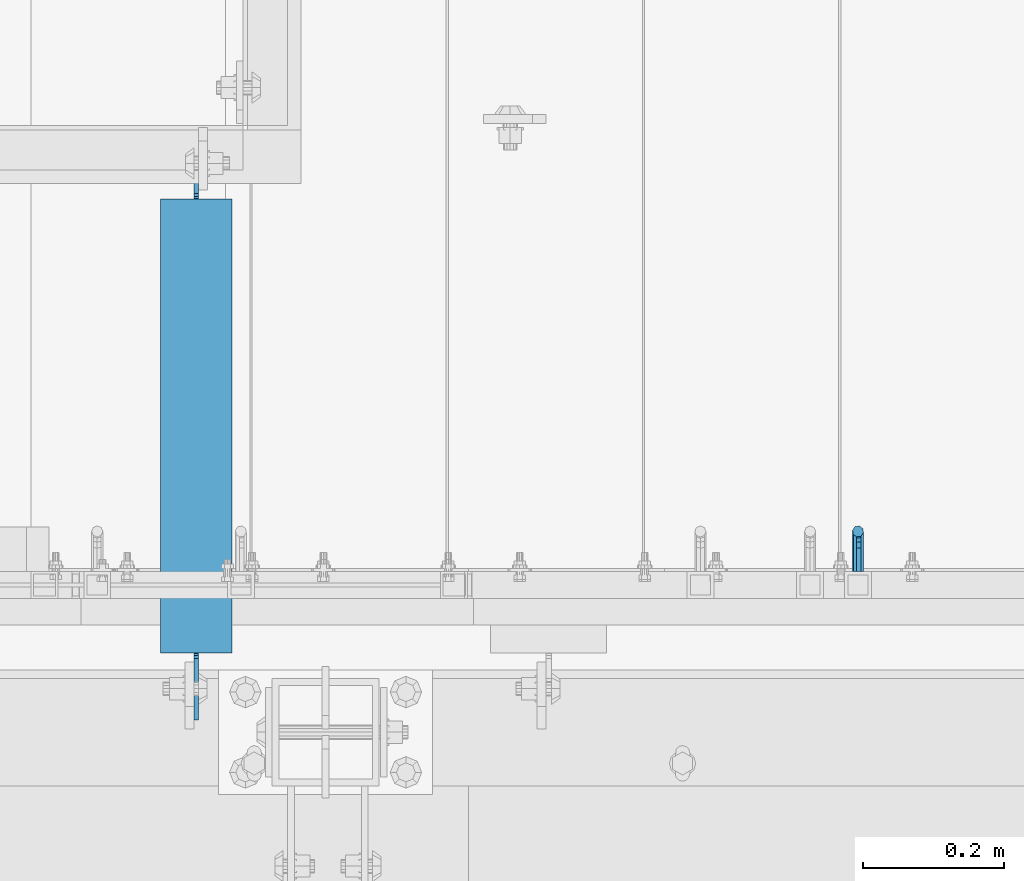
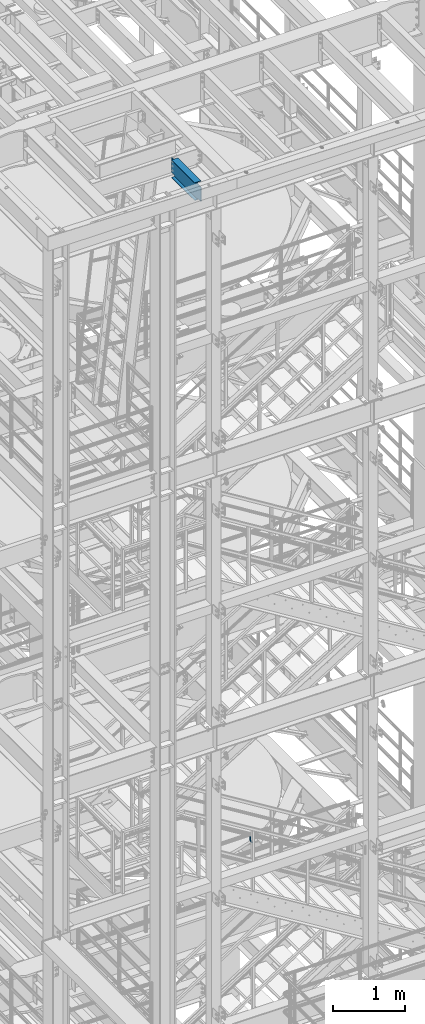
# One storey, part 1140 of 1876: 2 beams, 2 elements without a shape of their own.
"""IFC2X3 building model written with IfcOpenShell, lengths in millimetres."""

from ifc_helpers import new_model, si_unit, frame, origin_with_axes, place, context, subcontext, project, spatial, faceted_brep, material, type_object, element, aggregate, save


model = new_model("IFC2X3")

# Units and contexts
model_context = context("Model", 3, precision=1e-05, world=origin_with_axes())
body_context = subcontext(model_context, "Body", "Model", "MODEL_VIEW")
ifc_project = project(units=[si_unit("LENGTHUNIT", "METRE", prefix="MILLI"), si_unit("AREAUNIT", "SQUARE_METRE"), si_unit("VOLUMEUNIT", "CUBIC_METRE"), si_unit("MASSUNIT", "GRAM", prefix="KILO"), si_unit("TIMEUNIT", "SECOND"), si_unit("PLANEANGLEUNIT", "RADIAN"), si_unit("SOLIDANGLEUNIT", "STERADIAN"), si_unit("THERMODYNAMICTEMPERATUREUNIT", "DEGREE_CELSIUS"), si_unit("LUMINOUSINTENSITYUNIT", "LUMEN")], contexts=[model_context])

# Site, building, storey
site_placement = place(None, origin_with_axes())
site = spatial("IfcSite", under=ifc_project, at=site_placement, CompositionType="ELEMENT")
building_placement = place(site_placement, origin_with_axes())
building = spatial("IfcBuilding", under=site, at=building_placement, Name="Undefined", CompositionType="ELEMENT")
storey_placement = place(building_placement, origin_with_axes())
storey = spatial("IfcBuildingStorey", under=building, at=storey_placement, Name="Undefined", CompositionType="ELEMENT", Elevation=0.0)

# Assembly, beam
assembly_1_placement = place(storey_placement, origin_with_axes())
assembly_1 = element("IfcElementAssembly", 1, at=assembly_1_placement, inside=storey, Name="BEAM", AssemblyPlace="NOTDEFINED", PredefinedType="RIGID_FRAME")
ifc_material_1 = material(Name="STEEL/A992")
beam_type_1 = type_object("IfcBeamType", Name="W12X16", PredefinedType="NOTDEFINED")
beam_1_placement = place(assembly_1_placement, frame((2355.85, -7112.0, 22402.8), z_axis=(0.0, 0.0, 1.0), x_axis=(0.0, 1.0, 0.0)))
beam_1 = element("IfcBeam", 2, at=beam_1_placement, type_object=beam_type_1, material=ifc_material_1, Name="BEAM", ObjectType="W12X16", context=body_context, shape_type="Brep", body=[
    faceted_brep([(17.4625000000005, -3.17500000000018, -126.999999999999), (17.4625000000005, 3.17500000000018, -126.999999999999), (100.012500190734, 3.17500000000018, -126.999999999999), (100.012500190734, -3.17500000000018, -126.999999999999), (104.87257970878, 3.17500000000018, -127.966729922587), (104.87257970878, -3.17500000000018, -127.966729922587), (108.992756176934, 3.17500000000018, -130.719743823065), (108.992756176934, -3.17500000000018, -130.719743823065), (111.745770077412, 3.17500000000018, -134.839920291219), (111.745770077412, -3.17500000000018, -134.839920291219), (112.7125, -3.17500000000018, -139.699999809264), (112.7125, 3.17500000000018, -139.699999809264), (112.712500000001, 3.17500000000018, -146.049999999999), (112.7125, 50.8000000000002, -146.05), (112.7125, 50.8000000000002, -152.4), (112.7125, -50.8000000000002, -152.4), (112.7125, -50.8000000000002, -146.05), (112.712500000001, -3.17500000000018, -146.049999999999), (758.824999999998, 50.8000000000002, 146.049999999999), (758.824999999998, 3.17500000000018, 146.049999999999), (112.712500000001, 3.17500000000018, 146.05), (112.712500000001, 50.8000000000002, 146.049999999999), (100.012500190735, -3.17500000000018, 114.299999999996), (100.012500190735, 3.17500000000018, 114.299999999996), (17.4624999999996, 3.17500000000018, 114.299999999996), (17.4624999999996, -3.17500000000018, 114.299999999996), (104.872579708781, -3.17500000000018, 115.266729922583), (104.872579708781, 3.17500000000018, 115.266729922583), (108.992756176935, -3.17500000000018, 118.019743823061), (108.992756176935, 3.17500000000018, 118.019743823061), (111.745770077413, -3.17500000000018, 122.139920291214), (111.745770077413, 3.17500000000018, 122.139920291214), (112.712500000001, -3.17500000000018, 126.999999809261), (112.712500000001, 3.17500000000018, 126.999999809261), (758.824999999998, -50.8000000000002, 152.400000000001), (758.824999999998, 50.8000000000002, 152.400000000001), (112.712500000001, 50.8000000000002, 152.400000000001), (112.712500000001, -50.8000000000002, 152.400000000001), (758.824999999998, -50.8000000000002, 146.049999999999), (112.712500000001, -50.8000000000002, 146.049999999999), (758.824999999998, -3.17500000000018, 146.049999999999), (112.712500000001, -3.17500000000018, 146.05), (758.824999999998, -3.17500000000018, 139.699999809269), (758.824999999998, 3.17500000000018, 139.699999809269), (759.791729922586, -3.17500000000018, 134.839920291222), (759.791729922586, 3.17500000000018, 134.839920291222), (762.544743823064, -3.17500000000018, 130.719743823069), (762.544743823064, 3.17500000000018, 130.719743823069), (766.664920291218, -3.17500000000018, 127.966729922591), (766.664920291218, 3.17500000000018, 127.966729922591), (771.524999809263, -3.17500000000018, 127.000000000004), (771.524999809263, 3.17500000000018, 127.000000000004), (847.724999999999, -3.17500000000018, 127.000000000004), (847.724999999999, 3.17500000000018, 127.000000000004), (847.724999999999, -3.17500000000018, -126.999999999996), (847.724999999999, 3.17500000000018, -126.999999999996), (771.524999809263, -3.17500000000018, -126.999999999996), (771.524999809263, 3.17500000000018, -126.999999999996), (766.664920291218, -3.17500000000018, -127.966729922584), (766.664920291218, 3.17500000000018, -127.966729922584), (762.544743823064, -3.17500000000018, -130.719743823061), (762.544743823064, 3.17500000000018, -130.719743823061), (759.791729922586, -3.17500000000018, -134.839920291215), (759.791729922586, 3.17500000000018, -134.839920291215), (758.824999999998, -3.17500000000018, -139.699999809261), (758.824999999998, 3.17500000000018, -139.699999809261), (758.824999999998, -3.17500000000018, -146.049999999999), (758.824999999998, -50.8000000000002, -146.049999999999), (758.824999999998, -50.8000000000002, -152.400000000001), (758.824999999998, 50.8000000000002, -152.400000000001), (758.824999999998, 50.8000000000002, -146.049999999999), (758.824999999998, 3.17500000000018, -146.049999999999)], [[[0, 1, 2, 3]], [[3, 2, 4, 5]], [[5, 4, 6, 7]], [[7, 6, 8, 9]], [[10, 11, 12, 13, 14, 15, 16, 17]], [[9, 8, 11, 10]], [[18, 19, 20, 21]], [[22, 23, 24, 25]], [[26, 27, 23, 22]], [[28, 29, 27, 26]], [[30, 31, 29, 28]], [[32, 33, 31, 30]], [[34, 35, 36, 37]], [[38, 34, 37, 39]], [[40, 38, 39, 41]], [[37, 36, 21, 20, 33, 32, 41, 39]], [[35, 18, 21, 36]], [[34, 38, 40, 42, 43, 19, 18, 35]], [[44, 45, 43, 42]], [[46, 47, 45, 44]], [[48, 49, 47, 46]], [[50, 51, 49, 48]], [[52, 53, 51, 50]], [[53, 52, 54, 55]], [[54, 56, 57, 55]], [[58, 59, 57, 56]], [[60, 61, 59, 58]], [[62, 63, 61, 60]], [[64, 65, 63, 62]], [[66, 67, 68, 69, 70, 71, 65, 64]], [[67, 66, 17, 16]], [[68, 67, 16, 15]], [[69, 68, 15, 14]], [[70, 69, 14, 13]], [[71, 70, 13, 12]], [[6, 4, 2, 1, 24, 23, 27, 29, 31, 33, 20, 19, 43, 45, 47, 49, 51, 53, 55, 57, 59, 61, 63, 65, 71, 12, 11, 8]], [[25, 24, 1, 0]], [[66, 64, 62, 60, 58, 56, 54, 52, 50, 48, 46, 44, 42, 40, 41, 32, 30, 28, 26, 22, 25, 0, 3, 5, 7, 9, 10, 17]]]),
])
aggregate(assembly_1, [beam_1])

assembly_2_placement = place(storey_placement, origin_with_axes())
assembly_2 = element("IfcElementAssembly", 3, at=assembly_2_placement, inside=storey, Name="RAIL", AssemblyPlace="NOTDEFINED", PredefinedType="RIGID_FRAME")
ifc_material_2 = material(Name="STEEL/A36")
beam_type_2 = type_object("IfcBeamType", PredefinedType="NOTDEFINED")
beam_2_placement = place(assembly_2_placement, frame((3297.76666731711, -6883.39999885446, 10881.6358497101), z_axis=(-0.851746923791363, 0.0, 0.523953411871657), x_axis=(0.0, 1.0, 0.0)))
beam_2 = element("IfcBeam", 4, at=beam_2_placement, type_object=beam_type_2, material=ifc_material_2, Name="BRACKET", context=body_context, shape_type="Brep", body=[
    faceted_brep([(0.0, -5.61266007566822, 5.61266007566883), (0.0, 0.0, 7.9375), (0.0, 5.61266007566822, 5.61266007566883), (0.0, 7.9375, 0.0), (0.0, 5.61266007566822, -5.61266007566883), (0.0, 0.0, -7.9375), (0.0, -5.61266007566822, -5.61266007566883), (0.0, -7.9375, 0.0), (23.8125, 7.9375, 0.0), (23.8125, 5.61266007566883, -5.61266007566792), (23.8125, 0.0, -7.9375), (23.8125, -5.61266007566883, -5.61266007566792), (23.8125, -7.9375, 0.0), (23.8125, -5.61266007566883, 5.61266007566792), (23.8125, 0.0, 7.9375), (23.8125, 5.61266007566883, 5.61266007566792), (37.2742680237907, 3.33192699189385, 7.01565649095653), (39.15743316105, 5.33771543479088, 1.59926141794483), (39.5250377726497, 2.95059483544173, -3.97508660603592), (38.1617440627024, -2.43109193407145, -6.44201010992776), (35.8661509970007, -7.65482575261558, -4.3564187624853), (33.9829858597423, -9.66061419551443, 1.05997631052549), (33.6153812481443, -7.27349359616528, 6.63432433450714), (34.9786749580899, -1.89180682665028, 9.10124783839899), (44.4449010004428, -7.27921686651098, 12.4153212945938), (48.6866038971966, -3.16305132232992, 11.0110522507902), (41.9258626896017, -12.0031473096369, 9.54377798901703), (42.605107443027, -14.5676282658369, 4.07853345752562), (46.0847428963316, -13.4704215714119, -0.778946175020906), (50.3264457930854, -9.35425602723262, -2.18321521882456), (52.8454841039247, -4.63032558410305, 0.688328086752222), (52.1662393505012, -2.0658446279067, 6.15357261824545), (56.3120829365644, -12.8834732957839, 16.9905845690854), (60.8584457511233, -13.1460552819772, 12.9695810055836), (50.7700310236578, -15.3420457780048, 17.3751827270333), (47.4787488596085, -19.0815743126295, 13.8980830945646), (48.3662248985192, -21.9114938009589, 8.59612347865811), (52.9125877130791, -22.1740757871521, 4.57511991515719), (58.4546396259857, -19.715503304933, 4.19052175720924), (61.7459217900359, -15.9759747703083, 7.66762138967886), (63.9107427334729, -26.2160548977063, 21.0096110902649), (64.8713398759373, -29.3590804831365, 15.9002591648249), (58.9897950832947, -24.3494927988595, 24.0439238549806), (52.991121319149, -24.8528009490874, 23.2257381938842), (49.4286631758196, -27.4311482600406, 19.0343361707063), (50.389260318284, -30.5741738454726, 13.9249842452672), (55.3102079684622, -32.4407359443194, 10.8906714805506), (61.3088817326088, -31.9374277940915, 11.7088571416479), (64.8713398759373, -56.6704316393188, 32.700878247072), (61.3088817326088, -56.6704314004855, 26.9234018184987), (55.3102079684622, -56.670431353863, 25.7956053568267), (50.389260318284, -56.6704315267634, 29.9781367337081), (49.4286631758196, -56.6704318179036, 37.0209257936175), (52.991121319149, -56.6704320567369, 42.7984022221907), (58.9897950832947, -56.6704321033558, 43.9261986838618), (63.9107427334739, -56.6704319304572, 39.7436673069795)], [[[0, 1, 2, 3, 4, 5, 6, 7]], [[4, 3, 8, 9]], [[5, 4, 9, 10]], [[6, 5, 10, 11]], [[7, 6, 11, 12]], [[0, 7, 12, 13]], [[1, 0, 13, 14]], [[2, 1, 14, 15]], [[3, 2, 15, 8]], [[8, 15, 16, 17]], [[9, 8, 17, 18]], [[10, 9, 18, 19]], [[11, 10, 19, 20]], [[12, 11, 20, 21]], [[13, 12, 21, 22]], [[14, 13, 22, 23]], [[15, 14, 23, 16]], [[23, 24, 25, 16]], [[22, 26, 24, 23]], [[21, 27, 26, 22]], [[20, 28, 27, 21]], [[19, 29, 28, 20]], [[18, 30, 29, 19]], [[17, 31, 30, 18]], [[16, 25, 31, 17]], [[25, 32, 33, 31]], [[24, 34, 32, 25]], [[26, 35, 34, 24]], [[27, 36, 35, 26]], [[28, 37, 36, 27]], [[29, 38, 37, 28]], [[30, 39, 38, 29]], [[31, 33, 39, 30]], [[33, 40, 41, 39]], [[32, 42, 40, 33]], [[34, 43, 42, 32]], [[35, 44, 43, 34]], [[36, 45, 44, 35]], [[37, 46, 45, 36]], [[38, 47, 46, 37]], [[39, 41, 47, 38]], [[47, 41, 48, 49]], [[46, 47, 49, 50]], [[45, 46, 50, 51]], [[44, 45, 51, 52]], [[43, 44, 52, 53]], [[42, 43, 53, 54]], [[40, 42, 54, 55]], [[41, 40, 55, 48]], [[54, 53, 52, 51, 50, 49, 48, 55]]]),
])
aggregate(assembly_2, [beam_2])

save(model, "model.ifc")
